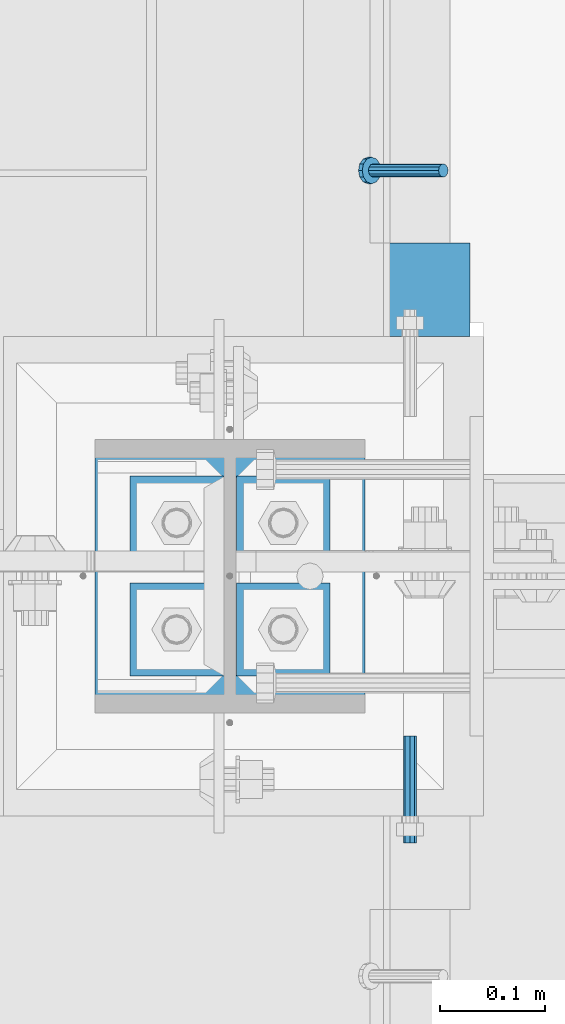
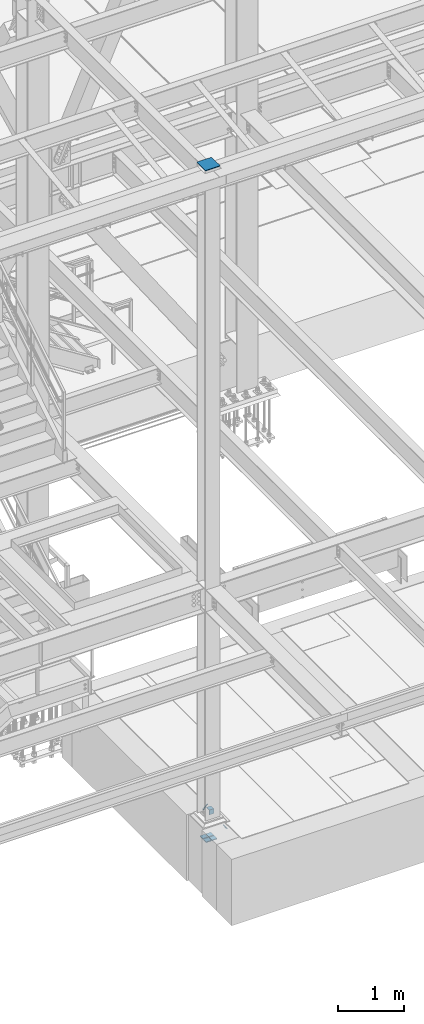
# One storey, part 2044 of 3843: 7 beams, 1 member, 5 elements without a shape of their own.
"""IFC2X3 building model written with IfcOpenShell, lengths in millimetres."""

from ifc_helpers import new_model, si_unit, frame, origin_with_axes, place, context, subcontext, project, spatial, faceted_brep, material, type_object, element, aggregate, save


model = new_model("IFC2X3")

# Units and contexts
model_context = context("Model", 3, precision=1e-05, world=origin_with_axes())
body_context = subcontext(model_context, "Body", "Model", "MODEL_VIEW")
ifc_project = project(units=[si_unit("LENGTHUNIT", "METRE", prefix="MILLI"), si_unit("AREAUNIT", "SQUARE_METRE"), si_unit("VOLUMEUNIT", "CUBIC_METRE"), si_unit("MASSUNIT", "GRAM", prefix="KILO"), si_unit("TIMEUNIT", "SECOND"), si_unit("PLANEANGLEUNIT", "RADIAN"), si_unit("SOLIDANGLEUNIT", "STERADIAN"), si_unit("THERMODYNAMICTEMPERATUREUNIT", "DEGREE_CELSIUS"), si_unit("LUMINOUSINTENSITYUNIT", "LUMEN")], contexts=[model_context])

# Site, building, storey
site_placement = place(None, origin_with_axes())
site = spatial("IfcSite", under=ifc_project, at=site_placement, CompositionType="ELEMENT")
building_placement = place(site_placement, origin_with_axes())
building = spatial("IfcBuilding", under=site, at=building_placement, Name="Undefined", CompositionType="ELEMENT")
storey_placement = place(building_placement, origin_with_axes())
storey = spatial("IfcBuildingStorey", under=building, at=storey_placement, Name="Undefined", CompositionType="ELEMENT", Elevation=0.0)

# Assembly, member
assembly_1_placement = place(storey_placement, origin_with_axes())
assembly_1 = element("IfcElementAssembly", 1, at=assembly_1_placement, inside=storey, Name="ANGLE", AssemblyPlace="NOTDEFINED", PredefinedType="RIGID_FRAME")
ifc_material_1 = material(Name="STEEL/A108")
member_type = type_object("IfcMemberType", PredefinedType="NOTDEFINED")
member_placement = place(assembly_1_placement, frame((56133.9999890706, 15385.2559998001, 30422.8500045777), z_axis=(0.0, -1.0, 0.0), x_axis=(-0.707106781186548, 0.0, -0.707106781186548)))
member = element("IfcMember", 2, at=member_placement, type_object=member_type, material=ifc_material_1, Name="HEADED STUD ANCHOR", context=body_context, shape_type="Brep", body=[
    faceted_brep([(7.27595761418343e-12, -3.18000006675175, 5.5), (0.0, -5.49999999998363, 3.1800000667572), (94.4879985803855, -5.50000000011278, 3.1800000667572), (94.4879985803782, -3.18000006687362, 5.5), (0.0, -6.3499999046162, 0.0), (94.4879985803855, -6.34999990474535, 0.0), (0.0, -5.49999999998363, -3.1800000667572), (94.4879985803855, -5.50000000011278, -3.1800000667572), (7.27595761418343e-12, -3.18000006675175, -5.5), (94.4879985803782, -3.18000006687362, -5.5), (7.27595761418343e-12, -1.81898940354586e-12, -6.34999990463257), (94.4879985803782, -1.20053300634027e-10, -6.34999990463257), (0.0, 3.18000006675175, -5.5), (94.4879985803709, 3.18000006663351, -5.5), (7.27595761418343e-12, 5.49999999998363, -3.1800000667572), (94.4879985803709, 5.49999999987267, -3.1800000667572), (7.27595761418343e-12, 6.3499999046162, 0.0), (94.4879985803673, 6.34999990450706, 0.0), (7.27595761418343e-12, 5.49999999998363, 3.1800000667572), (94.4879985803709, 5.49999999987267, 3.1800000667572), (0.0, 3.18000006675175, 5.5), (94.4879985803709, 3.18000006663351, 5.5), (7.27595761418343e-12, -1.81898940354586e-12, 6.34999990463257), (94.4879985803782, -1.20053300634027e-10, 6.34999990463257), (96.5199985498621, -10.9899997712273, 6.34999990463257), (96.5199985498548, -6.34000015270249, 10.9899997711182), (96.5199985498621, -12.6999998093743, 0.0), (96.5199985498621, -10.9899997712273, -6.34999990463257), (96.5199985498548, -6.34000015270249, -10.9899997711182), (96.5199985498475, -1.21872290037572e-10, -12.6899995803833), (96.5199985498402, 6.34000015245874, -10.9899997711182), (96.519998549833, 10.9899997709817, -6.34999990463257), (96.519998549833, 12.6999998091305, 0.0), (96.519998549833, 10.9899997709817, 6.34999990463257), (96.5199985498402, 6.34000015245874, 10.9899997711182), (96.5199985498475, -1.21872290037572e-10, 12.6899995803833), (101.599998473539, -10.9899997712328, 6.34999990463257), (101.599998473532, -6.34000015270976, 10.9899997711182), (101.599998473539, -12.6999998093797, 0.0), (101.599998473539, -10.9899997712328, -6.34999990463257), (101.599998473532, -6.34000015270976, -10.9899997711182), (101.599998473524, -1.29148247651756e-10, -12.6899995803833), (101.599998473517, 6.34000015245329, -10.9899997711182), (101.59999847351, 10.9899997709763, -6.34999990463257), (101.599998473503, 12.6999998091196, 0.0), (101.59999847351, 10.9899997709763, 6.34999990463257), (101.599998473517, 6.34000015245329, 10.9899997711182), (101.599998473524, -1.29148247651756e-10, 12.6899995803833)], [[[0, 1, 2, 3]], [[1, 4, 5, 2]], [[4, 6, 7, 5]], [[6, 8, 9, 7]], [[8, 10, 11, 9]], [[10, 12, 13, 11]], [[12, 14, 15, 13]], [[14, 16, 17, 15]], [[16, 18, 19, 17]], [[18, 20, 21, 19]], [[20, 22, 23, 21]], [[22, 0, 3, 23]], [[22, 20, 18, 16, 14, 12, 10, 8, 6, 4, 1, 0]], [[3, 2, 24, 25]], [[2, 5, 26, 24]], [[5, 7, 27, 26]], [[7, 9, 28, 27]], [[9, 11, 29, 28]], [[11, 13, 30, 29]], [[13, 15, 31, 30]], [[15, 17, 32, 31]], [[17, 19, 33, 32]], [[19, 21, 34, 33]], [[21, 23, 35, 34]], [[23, 3, 25, 35]], [[25, 24, 36, 37]], [[24, 26, 38, 36]], [[26, 27, 39, 38]], [[27, 28, 40, 39]], [[28, 29, 41, 40]], [[29, 30, 42, 41]], [[30, 31, 43, 42]], [[31, 32, 44, 43]], [[32, 33, 45, 44]], [[33, 34, 46, 45]], [[34, 35, 47, 46]], [[35, 25, 37, 47]], [[38, 39, 40, 41, 42, 43, 44, 45, 46, 47, 37, 36]]]),
])
aggregate(assembly_1, [member])

# Assembly, beam
assembly_2_placement = place(storey_placement, origin_with_axes())
assembly_2 = element("IfcElementAssembly", 3, at=assembly_2_placement, inside=storey, Name="GRATING", AssemblyPlace="NOTDEFINED", PredefinedType="NOTDEFINED")
ifc_material_2 = material(Name="STEEL/A36")
beam_type_1 = type_object("IfcBeamType", Name="L3-1/2X3-1/2X1/4", PredefinedType="NOTDEFINED")
beam_1_placement = place(assembly_2_placement, frame((56076.850075577, 15271.7501304875, 30384.7500045777), z_axis=(0.0, 0.0, -1.0), x_axis=(0.999999999998918, -1.47099999831629e-06, 0.0)))
beam_1 = element("IfcBeam", 4, at=beam_1_placement, type_object=beam_type_1, material=ifc_material_2, Name="ANGLE", ObjectType="L3-1/2X3-1/2X1/4", context=body_context, shape_type="Brep", body=[
    faceted_brep([(-3.63797880709171e-12, 44.4499999999971, -44.4500000000007), (-3.63797880709171e-12, 44.4499999999971, 44.4500000000007), (82.5499948264842, 44.4499999999425, 44.4500000000007), (82.5499948264842, 44.4499999999425, -44.4500000000007), (-3.63797880709171e-11, 38.1000000000149, 44.4500000000007), (82.5499948264696, 38.0999999999458, 44.4500000000007), (0.0, 38.0999999999985, -38.0999999999985), (82.5499948264696, 38.0999999999458, -38.0999999999985), (4.36557456851006e-11, -44.4500000000226, -38.0999999999985), (82.5499948262877, -44.450000000008, -38.0999999999985), (3.63797880709171e-12, -44.4499999999971, -44.4500000000007), (82.5499948262877, -44.450000000008, -44.4500000000007)], [[[0, 1, 2, 3]], [[1, 4, 5, 2]], [[4, 6, 7, 5]], [[6, 8, 9, 7]], [[8, 10, 11, 9]], [[10, 0, 3, 11]], [[5, 7, 9, 11, 3, 2]], [[10, 8, 6, 4, 1, 0]]]),
])
aggregate(assembly_2, [beam_1])

assembly_3_placement = place(storey_placement, origin_with_axes())
assembly_3 = element("IfcElementAssembly", 5, at=assembly_3_placement, inside=storey, Name="EPOXY BOLT", AssemblyPlace="NOTDEFINED", PredefinedType="RIGID_FRAME")
ifc_material_3 = material(Name="STEEL/A307")
beam_type_2 = type_object("IfcBeamType", PredefinedType="NOTDEFINED")
beam_2_placement = place(assembly_3_placement, frame((56102.2501800578, 14744.6999392318, 30378.4), z_axis=(0.0, 0.0, -1.0), x_axis=(0.0, 1.0, 0.0)))
beam_2 = element("IfcBeam", 6, at=beam_2_placement, type_object=beam_type_2, material=ifc_material_3, Name="EPOXY BOLT", context=body_context, shape_type="Brep", body=[
    faceted_brep([(0.0, -6.3499999046162, 0.0), (0.0, -4.49012806053361, -4.49012806053361), (101.6, -4.49012806053361, -4.49012806053361), (101.6, -6.34999999999854, 0.0), (7.27595761418343e-12, -1.81898940354586e-12, -6.34999990463257), (101.6, 0.0, -6.34999999999854), (0.0, 4.49012806053361, -4.49012806053361), (101.6, 4.49012806053361, -4.49012806053361), (7.27595761418343e-12, 6.3499999046162, 0.0), (101.6, 6.34999999999854, 0.0), (0.0, 4.49012806053361, 4.49012806053361), (101.6, 4.49012806053361, 4.49012806053361), (7.27595761418343e-12, -1.81898940354586e-12, 6.34999990463257), (101.6, 0.0, 6.34999999999854), (0.0, -4.49012806053361, 4.49012806053361), (101.6, -4.49012806053361, 4.49012806053361)], [[[0, 1, 2, 3]], [[1, 4, 5, 2]], [[4, 6, 7, 5]], [[6, 8, 9, 7]], [[8, 10, 11, 9]], [[10, 12, 13, 11]], [[12, 14, 15, 13]], [[14, 0, 3, 15]], [[5, 7, 9, 11, 13, 15, 3, 2]], [[14, 12, 10, 8, 6, 4, 1, 0]]]),
])
aggregate(assembly_3, [beam_2])

# Assembly, beams
assembly_4_placement = place(storey_placement, origin_with_axes())
assembly_4 = element("IfcElementAssembly", 7, at=assembly_4_placement, inside=storey, Name="TEMPLATE", AssemblyPlace="NOTDEFINED", PredefinedType="RIGID_FRAME")
ifc_material_4 = material(Name="STEEL/A572-50")
beam_type_3 = type_object("IfcBeamType", PredefinedType="NOTDEFINED")
beam_3_placement = place(assembly_4_placement, frame((55880.0, 14903.45, 30116.4625), z_axis=(1.0, 0.0, 0.0), x_axis=(0.0, 1.0, 0.0)))
beam_3 = element("IfcBeam", 8, at=beam_3_placement, type_object=beam_type_3, material=ifc_material_4, context=body_context, shape_type="Brep", body=[
    faceted_brep([(0.0, 7.9375, -44.4499999999971), (0.0, 7.9375, 44.4499999999971), (88.8999999999942, 7.9375, 44.4499999999971), (88.8999999999942, 7.9375, -44.4499999999971), (0.0, -7.9375, 44.4499999999971), (88.8999999999942, -7.9375, 44.4499999999971), (0.0, -7.9375, -44.4499999999971), (88.8999999999942, -7.9375, -44.4499999999971)], [[[0, 1, 2, 3]], [[1, 4, 5, 2]], [[4, 6, 7, 5]], [[6, 0, 3, 7]], [[5, 7, 3, 2]], [[6, 4, 1, 0]]]),
])
beam_4_placement = place(assembly_4_placement, frame((55981.6, 14903.45, 30116.4625), z_axis=(1.0, 0.0, 0.0), x_axis=(0.0, 1.0, 0.0)))
beam_4 = element("IfcBeam", 9, at=beam_4_placement, type_object=beam_type_3, material=ifc_material_4, context=body_context, shape_type="Brep", body=[
    faceted_brep([(0.0, 7.9375, -44.4499999999971), (0.0, 7.9375, 44.4499999999971), (88.8999999999942, 7.9375, 44.4499999999971), (88.8999999999942, 7.9375, -44.4499999999971), (0.0, -7.9375, 44.4499999999971), (88.8999999999942, -7.9375, 44.4499999999971), (0.0, -7.9375, -44.4499999999971), (88.8999999999942, -7.9375, -44.4499999999971)], [[[0, 1, 2, 3]], [[1, 4, 5, 2]], [[4, 6, 7, 5]], [[6, 0, 3, 7]], [[5, 7, 3, 2]], [[6, 4, 1, 0]]]),
])
beam_5_placement = place(assembly_4_placement, frame((55880.0, 15005.05, 30116.4625), z_axis=(1.0, 0.0, 0.0), x_axis=(0.0, 1.0, 0.0)))
beam_5 = element("IfcBeam", 10, at=beam_5_placement, type_object=beam_type_3, material=ifc_material_4, context=body_context, shape_type="Brep", body=[
    faceted_brep([(0.0, 7.9375, -44.4499999999971), (0.0, 7.9375, 44.4499999999971), (88.8999999999942, 7.9375, 44.4499999999971), (88.8999999999942, 7.9375, -44.4499999999971), (0.0, -7.9375, 44.4499999999971), (88.8999999999942, -7.9375, 44.4499999999971), (0.0, -7.9375, -44.4499999999971), (88.8999999999942, -7.9375, -44.4499999999971)], [[[0, 1, 2, 3]], [[1, 4, 5, 2]], [[4, 6, 7, 5]], [[6, 0, 3, 7]], [[5, 7, 3, 2]], [[6, 4, 1, 0]]]),
])
beam_6_placement = place(assembly_4_placement, frame((55981.6, 15005.05, 30116.4625), z_axis=(1.0, 0.0, 0.0), x_axis=(0.0, 1.0, 0.0)))
beam_6 = element("IfcBeam", 11, at=beam_6_placement, type_object=beam_type_3, material=ifc_material_4, context=body_context, shape_type="Brep", body=[
    faceted_brep([(0.0, 7.9375, -44.4499999999971), (0.0, 7.9375, 44.4499999999971), (88.8999999999942, 7.9375, 44.4499999999971), (88.8999999999942, 7.9375, -44.4499999999971), (0.0, -7.9375, 44.4499999999971), (88.8999999999942, -7.9375, 44.4499999999971), (0.0, -7.9375, -44.4499999999971), (88.8999999999942, -7.9375, -44.4499999999971)], [[[0, 1, 2, 3]], [[1, 4, 5, 2]], [[4, 6, 7, 5]], [[6, 0, 3, 7]], [[5, 7, 3, 2]], [[6, 4, 1, 0]]]),
])
aggregate(assembly_4, [beam_3, beam_4, beam_5, beam_6])

# Assembly, beam
assembly_5_placement = place(storey_placement, origin_with_axes())
assembly_5 = element("IfcElementAssembly", 12, at=assembly_5_placement, inside=storey, Name="COLUMN", AssemblyPlace="NOTDEFINED", PredefinedType="RIGID_FRAME")
beam_type_4 = type_object("IfcBeamType", PredefinedType="NOTDEFINED")
beam_7_placement = place(assembly_5_placement, frame((55930.8, 14868.525, 42513.25), z_axis=(1.0, 0.0, 0.0), x_axis=(0.0, 1.0, 0.0)))
beam_7 = element("IfcBeam", 13, at=beam_7_placement, type_object=beam_type_4, material=ifc_material_4, Name="PLATE", context=body_context, shape_type="Brep", body=[
    faceted_brep([(0.0, 6.34999999999854, -128.587499999994), (0.0, 6.34999999999854, 128.587500000009), (260.350000000006, 6.34999999999854, 128.587499999994), (260.350000000006, 6.34999999999854, -128.587499999994), (0.0, -6.34999999999854, 128.587500000009), (260.350000000006, -6.34999999999854, 128.587499999994), (0.0, -6.34999999999854, -128.587499999994), (260.350000000006, -6.34999999999854, -128.587499999994)], [[[0, 1, 2, 3]], [[1, 4, 5, 2]], [[4, 6, 7, 5]], [[6, 0, 3, 7]], [[5, 7, 3, 2]], [[6, 4, 1, 0]]]),
])
aggregate(assembly_5, [beam_7])

save(model, "model.ifc")
